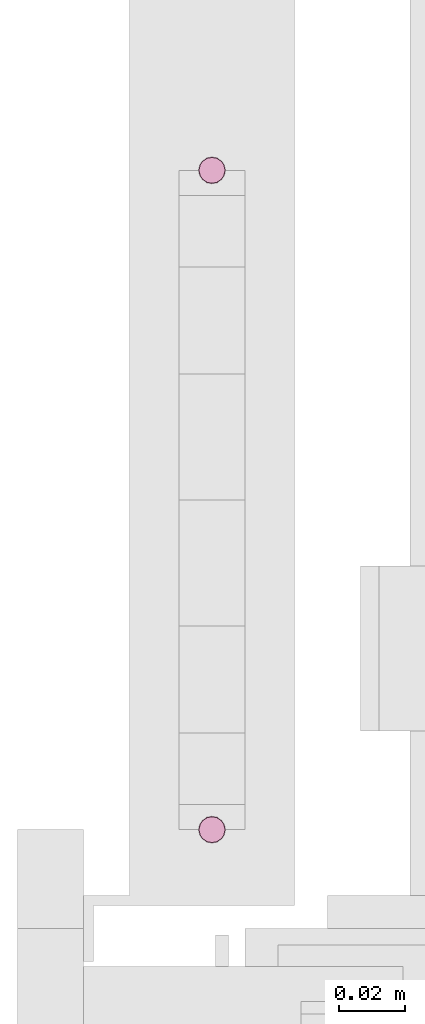
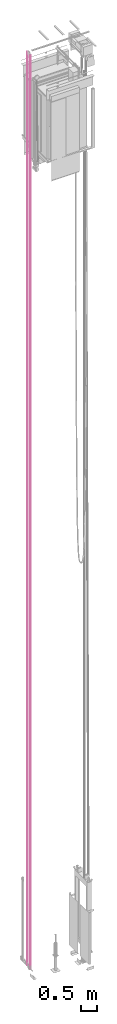
# One storey, part 7 of 13: 1 transport element.
"""IFC4 building model written with IfcOpenShell, lengths in millimetres."""

from ifc_helpers import new_model, entity, si_unit, converted_unit, frame, origin_with_axes, place, context, subcontext, project, spatial, faceted_brep, element, save


model = new_model("IFC4")

# Units and contexts
context_of_model = context(None, 3, precision=0.01, world=origin_with_axes())
sub_context = subcontext(context_of_model, None, None, "MODEL_VIEW")
ifc_project = project(units=[converted_unit("PLANEANGLEUNIT", "degree", entity("IfcPlaneAngleMeasure", 0.017453292519943), si_unit("PLANEANGLEUNIT", "RADIAN"), dimensions=[0, 0, 0, 0, 0, 0, 0]), si_unit("LENGTHUNIT", "METRE", prefix="MILLI"), si_unit("MASSUNIT", "GRAM", prefix="KILO"), converted_unit("TIMEUNIT", "year", entity("IfcTimeMeasure", 31557600.0), si_unit("TIMEUNIT", "SECOND"), dimensions=[0, 0, 1, 0, 0, 0, 0]), si_unit("THERMODYNAMICTEMPERATUREUNIT", "DEGREE_CELSIUS"), si_unit("AREAUNIT", "SQUARE_METRE"), si_unit("FORCEUNIT", "NEWTON"), si_unit("VOLUMEUNIT", "CUBIC_METRE"), si_unit("PRESSUREUNIT", "PASCAL"), si_unit("SOLIDANGLEUNIT", "STERADIAN")], contexts=[context_of_model])

# Site, building, storey
site = spatial("IfcSite", under=ifc_project)
building = spatial("IfcBuilding", under=site, Name="Document")
placement = place(None, origin_with_axes())
storey_placement = place(placement, frame((0.0, 0.0, -26400.0), z_axis=(0.0, 0.0, 1.0), x_axis=(1.0, 0.0, 0.0)))
storey = spatial("IfcBuildingStorey", under=building, at=storey_placement, Name="Z -26400", Elevation=-26400.0)

# Transport element
transport_element_placement = place(storey_placement, origin_with_axes())
element("IfcTransportElement", 1, at=transport_element_placement, inside=storey, Name="GR", ObjectType="Rope", PredefinedType="ELEVATOR", context=sub_context, shape_type="Brep", body=[
    faceted_brep([(102.17156982421875, 1382.171630859375, 245.0), (102.17156982421875, 1382.171630859375, 34644.0), (101.30448150634766, 1383.46923828125, 34644.0), (101.30448150634766, 1383.46923828125, 245.0), (101.0, 1385.0, 245.0), (101.30448150634766, 1386.53076171875, 245.0), (102.17156982421875, 1387.828369140625, 245.0), (103.46926879882812, 1388.695556640625, 245.0), (105.0, 1389.0, 245.0), (106.53073120117188, 1388.695556640625, 245.0), (107.82843017578125, 1387.828369140625, 245.0), (108.69551849365234, 1386.53076171875, 245.0), (109.0, 1385.0, 245.0), (108.69551849365234, 1383.46923828125, 245.0), (107.82843017578125, 1382.171630859375, 245.0), (106.53073120117188, 1381.304443359375, 245.0), (105.0, 1381.0, 245.0), (103.46926879882812, 1381.304443359375, 245.0), (101.0, 1385.0, 34644.0), (103.46926879882812, 1381.304443359375, 34644.0), (101.30448150634766, 1386.53076171875, 34644.0), (105.0, 1381.0, 34644.0), (102.17156982421875, 1387.828369140625, 34644.0), (106.53073120117188, 1381.304443359375, 34644.0), (103.46926879882812, 1388.695556640625, 34644.0), (107.82843017578125, 1382.171630859375, 34644.0), (105.0, 1389.0, 34644.0), (108.69551849365234, 1383.46923828125, 34644.0), (106.53073120117188, 1388.695556640625, 34644.0), (109.0, 1385.0, 34644.0), (107.82843017578125, 1387.828369140625, 34644.0), (108.69551849365234, 1386.53076171875, 34644.0)], [[[0, 1, 2, 3]], [[4, 5, 6, 7, 8, 9, 10, 11, 12, 13, 14, 15, 16, 17, 0, 3]], [[2, 18, 4, 3]], [[17, 19, 1, 0]], [[18, 20, 5, 4]], [[16, 21, 19, 17]], [[20, 22, 6, 5]], [[15, 23, 21, 16]], [[22, 24, 7, 6]], [[14, 25, 23, 15]], [[24, 26, 8, 7]], [[13, 27, 25, 14]], [[26, 28, 9, 8]], [[12, 29, 27, 13]], [[28, 30, 10, 9]], [[11, 31, 29, 12]], [[30, 31, 11, 10]], [[1, 19, 21, 23, 25, 27, 29, 31, 30, 28, 26, 24, 22, 20, 18, 2]]]),
    faceted_brep([(102.17156982421875, 1182.171630859375, 245.0), (102.17156982421875, 1182.171630859375, 34644.0), (101.30448150634766, 1183.46923828125, 34644.0), (101.30448150634766, 1183.46923828125, 245.0), (101.0, 1185.0, 245.0), (101.30448150634766, 1186.53076171875, 245.0), (102.17156982421875, 1187.828369140625, 245.0), (103.46926879882812, 1188.695556640625, 245.0), (105.0, 1189.0, 245.0), (106.53073120117188, 1188.695556640625, 245.0), (107.82843017578125, 1187.828369140625, 245.0), (108.69551849365234, 1186.53076171875, 245.0), (109.0, 1185.0, 245.0), (108.69551849365234, 1183.46923828125, 245.0), (107.82843017578125, 1182.171630859375, 245.0), (106.53073120117188, 1181.304443359375, 245.0), (105.0, 1181.0, 245.0), (103.46926879882812, 1181.304443359375, 245.0), (101.0, 1185.0, 34644.0), (103.46926879882812, 1181.304443359375, 34644.0), (101.30448150634766, 1186.53076171875, 34644.0), (105.0, 1181.0, 34644.0), (102.17156982421875, 1187.828369140625, 34644.0), (106.53073120117188, 1181.304443359375, 34644.0), (103.46926879882812, 1188.695556640625, 34644.0), (107.82843017578125, 1182.171630859375, 34644.0), (105.0, 1189.0, 34644.0), (108.69551849365234, 1183.46923828125, 34644.0), (106.53073120117188, 1188.695556640625, 34644.0), (109.0, 1185.0, 34644.0), (107.82843017578125, 1187.828369140625, 34644.0), (108.69551849365234, 1186.53076171875, 34644.0)], [[[0, 1, 2, 3]], [[4, 5, 6, 7, 8, 9, 10, 11, 12, 13, 14, 15, 16, 17, 0, 3]], [[2, 18, 4, 3]], [[17, 19, 1, 0]], [[18, 20, 5, 4]], [[16, 21, 19, 17]], [[20, 22, 6, 5]], [[15, 23, 21, 16]], [[22, 24, 7, 6]], [[14, 25, 23, 15]], [[24, 26, 8, 7]], [[13, 27, 25, 14]], [[26, 28, 9, 8]], [[12, 29, 27, 13]], [[28, 30, 10, 9]], [[11, 31, 29, 12]], [[30, 31, 11, 10]], [[1, 19, 21, 23, 25, 27, 29, 31, 30, 28, 26, 24, 22, 20, 18, 2]]]),
])

save(model, "model.ifc")
